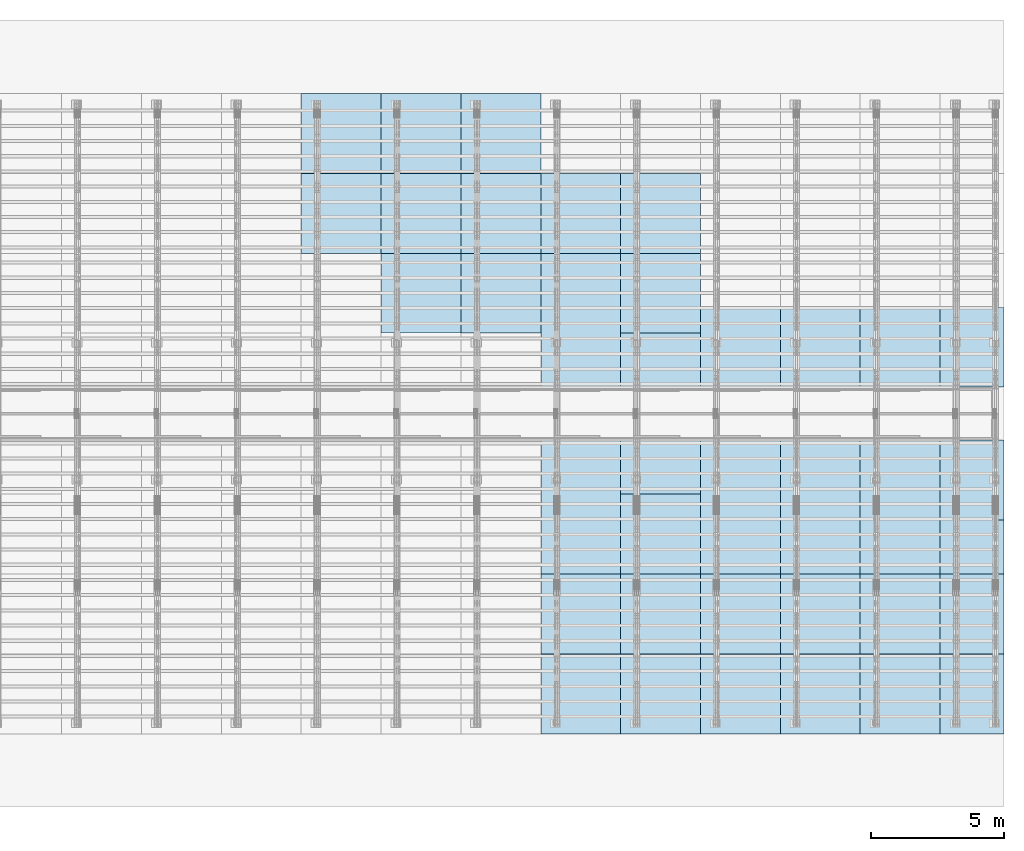
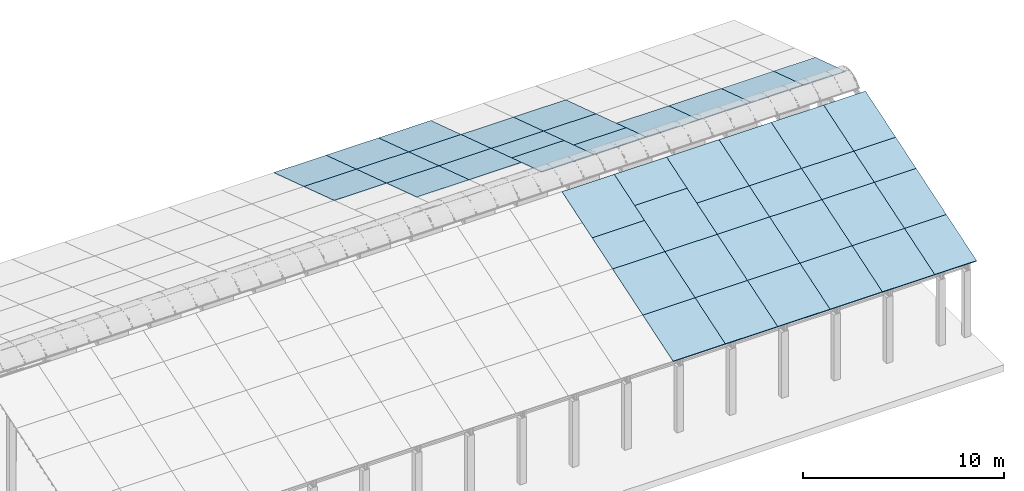
# One storey, part 9 of 385: 42 slabs, 42 elements without a shape of their own.
"""IFC2X3 building model written with IfcOpenShell, lengths in millimetres."""

from ifc_helpers import new_model, entity, si_unit, converted_unit, derived_unit, direction, frame, frame_2d, origin, place, context, subcontext, project, spatial, rectangle, extrude, material, layer, layer_set, element, aggregate, save


model = new_model("IFC2X3")

# Units and contexts
model_context = context("Model", 3, precision=0.01, world=origin(), true_north=direction((6.12303176911189e-17, 1.0)))
body_context = subcontext(model_context, "Body", "Model", "MODEL_VIEW")
ifc_project = project(units=[si_unit("LENGTHUNIT", "METRE", prefix="MILLI"), si_unit("AREAUNIT", "SQUARE_METRE"), si_unit("VOLUMEUNIT", "CUBIC_METRE"), converted_unit("PLANEANGLEUNIT", "DEGREE", entity("IfcRatioMeasure", 0.0174532925199433), si_unit("PLANEANGLEUNIT", "RADIAN"), dimensions=[0, 0, 0, 0, 0, 0, 0]), si_unit("MASSUNIT", "GRAM", prefix="KILO"), derived_unit("MASSDENSITYUNIT", [(si_unit("MASSUNIT", "GRAM", prefix="KILO"), 1), (si_unit("LENGTHUNIT", "METRE"), -3)]), si_unit("TIMEUNIT", "SECOND"), si_unit("FREQUENCYUNIT", "HERTZ"), si_unit("THERMODYNAMICTEMPERATUREUNIT", "DEGREE_CELSIUS"), derived_unit("THERMALTRANSMITTANCEUNIT", [(si_unit("MASSUNIT", "GRAM", prefix="KILO"), 1), (si_unit("THERMODYNAMICTEMPERATUREUNIT", "KELVIN"), -1), (si_unit("TIMEUNIT", "SECOND"), -3)]), derived_unit("VOLUMETRICFLOWRATEUNIT", [(si_unit("LENGTHUNIT", "METRE"), 3), (si_unit("TIMEUNIT", "SECOND"), -1)]), si_unit("ELECTRICCURRENTUNIT", "AMPERE"), si_unit("ELECTRICVOLTAGEUNIT", "VOLT"), si_unit("POWERUNIT", "WATT"), si_unit("FORCEUNIT", "NEWTON", prefix="KILO"), si_unit("ILLUMINANCEUNIT", "LUX"), si_unit("LUMINOUSFLUXUNIT", "LUMEN"), si_unit("LUMINOUSINTENSITYUNIT", "CANDELA"), derived_unit("USERDEFINED", [(si_unit("MASSUNIT", "GRAM", prefix="KILO"), -1), (si_unit("LENGTHUNIT", "METRE"), -2), (si_unit("TIMEUNIT", "SECOND"), 3), (si_unit("LUMINOUSFLUXUNIT", "LUMEN"), 1)]), derived_unit("LINEARVELOCITYUNIT", [(si_unit("LENGTHUNIT", "METRE"), 1), (si_unit("TIMEUNIT", "SECOND"), -1)]), si_unit("PRESSUREUNIT", "PASCAL"), derived_unit("USERDEFINED", [(si_unit("LENGTHUNIT", "METRE"), -2), (si_unit("MASSUNIT", "GRAM", prefix="KILO"), 1), (si_unit("TIMEUNIT", "SECOND"), -2)])], contexts=[model_context])

# Site, building, storey
site_placement = place(None, origin())
site = spatial("IfcSite", under=ifc_project, at=site_placement, CompositionType="ELEMENT")
building_placement = place(site_placement, origin())
building = spatial("IfcBuilding", under=site, at=building_placement, CompositionType="ELEMENT")
storey_placement = place(building_placement, origin())
storey = spatial("IfcBuildingStorey", under=building, at=storey_placement, Name="Default", CompositionType="ELEMENT", Elevation=0.0)

# Roof, slab
roof_1_placement = place(storey_placement, frame((23674.5090412161, 23742.4435684861, 594.897947736069)))
roof_1 = element("IfcRoof", 1, at=roof_1_placement, inside=storey, ShapeType="NOTDEFINED")
ifc_material = material()
ifc_layer = layer(ifc_material, 40.0)
ifc_layer_set = layer_set([ifc_layer])
slab_1_placement = place(roof_1_placement, origin())
slab_1 = element("IfcSlab", 2, at=slab_1_placement, material=ifc_layer_set, PredefinedType="ROOF", context=body_context, shape_type="SweptSolid", body=[
    extrude(rectangle(XDim=3154.3866727148, YDim=2999.99999999999, at=frame_2d((0.0, 2.1600499167107e-12), x_axis=(0.0, 1.0))), frame((1500.0, 1500.0, 487.379544349359), z_axis=(0.0, 0.309016994374947, 0.951056516295154), x_axis=(1.0, 0.0, 0.0)), (0.0, -0.309016994374947, 0.951056516295154), 42.0584889695308),
])
aggregate(roof_1, [slab_1])

roof_2_placement = place(storey_placement, frame((23674.5090412161, 20742.4435684861, 1569.65703643478)))
roof_2 = element("IfcRoof", 3, at=roof_2_placement, inside=storey, ShapeType="NOTDEFINED")
slab_2_placement = place(roof_2_placement, origin())
slab_2 = element("IfcSlab", 4, at=slab_2_placement, material=ifc_layer_set, PredefinedType="ROOF", context=body_context, shape_type="SweptSolid", body=[
    extrude(rectangle(XDim=3154.3866727148, YDim=2999.99999999999, at=frame_2d((-2.1600499167107e-12, 1.13686837721616e-13), x_axis=(0.0, 1.0))), frame((1500.0, 1500.0, 487.379544349359), z_axis=(0.0, 0.309016994374947, 0.951056516295154), x_axis=(1.0, 0.0, 0.0)), (0.0, -0.309016994374947, 0.951056516295154), 42.0584889695308),
])
aggregate(roof_2, [slab_2])

roof_3_placement = place(storey_placement, frame((26674.5090412161, 23742.4435684861, 594.897947736069)))
roof_3 = element("IfcRoof", 5, at=roof_3_placement, inside=storey, ShapeType="NOTDEFINED")
slab_3_placement = place(roof_3_placement, origin())
slab_3 = element("IfcSlab", 6, at=slab_3_placement, material=ifc_layer_set, PredefinedType="ROOF", context=body_context, shape_type="SweptSolid", body=[
    extrude(rectangle(XDim=3154.3866727148, YDim=2999.99999999999, at=frame_2d((0.0, 2.1600499167107e-12), x_axis=(0.0, 1.0))), frame((1500.0, 1500.0, 487.379544349359), z_axis=(0.0, 0.309016994374947, 0.951056516295154), x_axis=(1.0, 0.0, 0.0)), (0.0, -0.309016994374947, 0.951056516295154), 42.0584889695308),
])
aggregate(roof_3, [slab_3])

roof_4_placement = place(storey_placement, frame((26674.5090412161, 20742.4435684861, 1569.65703643478)))
roof_4 = element("IfcRoof", 7, at=roof_4_placement, inside=storey, ShapeType="NOTDEFINED")
slab_4_placement = place(roof_4_placement, origin())
slab_4 = element("IfcSlab", 8, at=slab_4_placement, material=ifc_layer_set, PredefinedType="ROOF", context=body_context, shape_type="SweptSolid", body=[
    extrude(rectangle(XDim=3154.3866727148, YDim=2999.99999999999, at=frame_2d((-2.1600499167107e-12, 1.13686837721616e-13), x_axis=(0.0, 1.0))), frame((1500.0, 1500.0, 487.379544349359), z_axis=(0.0, 0.309016994374947, 0.951056516295154), x_axis=(1.0, 0.0, 0.0)), (0.0, -0.309016994374947, 0.951056516295154), 42.0584889695308),
])
aggregate(roof_4, [slab_4])

roof_5_placement = place(storey_placement, frame((26674.5090412161, 17742.4435684861, 2544.4161251335)))
roof_5 = element("IfcRoof", 9, at=roof_5_placement, inside=storey, ShapeType="NOTDEFINED")
slab_5_placement = place(roof_5_placement, origin())
slab_5 = element("IfcSlab", 10, at=slab_5_placement, material=ifc_layer_set, PredefinedType="ROOF", context=body_context, shape_type="SweptSolid", body=[
    extrude(rectangle(XDim=3154.3866727148, YDim=2999.99999999999, at=frame_2d((0.0, 1.13686837721616e-12), x_axis=(0.0, 1.0))), frame((1500.0, 1500.0, 487.379544349359), z_axis=(0.0, 0.309016994374947, 0.951056516295154), x_axis=(1.0, 0.0, 0.0)), (0.0, -0.309016994374947, 0.951056516295154), 42.0584889695308),
])
aggregate(roof_5, [slab_5])

roof_6_placement = place(storey_placement, frame((29674.5090412161, 23742.4435684861, 594.897947736069)))
roof_6 = element("IfcRoof", 11, at=roof_6_placement, inside=storey, ShapeType="NOTDEFINED")
slab_6_placement = place(roof_6_placement, origin())
slab_6 = element("IfcSlab", 12, at=slab_6_placement, material=ifc_layer_set, PredefinedType="ROOF", context=body_context, shape_type="SweptSolid", body=[
    extrude(rectangle(XDim=3154.3866727148, YDim=2999.99999999999, at=frame_2d((0.0, 2.1600499167107e-12), x_axis=(0.0, 1.0))), frame((1500.0, 1500.0, 487.379544349359), z_axis=(0.0, 0.309016994374947, 0.951056516295154), x_axis=(1.0, 0.0, 0.0)), (0.0, -0.309016994374947, 0.951056516295154), 42.0584889695308),
])
aggregate(roof_6, [slab_6])

roof_7_placement = place(storey_placement, frame((29674.5090412161, 20742.4435684861, 1569.65703643478)))
roof_7 = element("IfcRoof", 13, at=roof_7_placement, inside=storey, ShapeType="NOTDEFINED")
slab_7_placement = place(roof_7_placement, origin())
slab_7 = element("IfcSlab", 14, at=slab_7_placement, material=ifc_layer_set, PredefinedType="ROOF", context=body_context, shape_type="SweptSolid", body=[
    extrude(rectangle(XDim=3154.3866727148, YDim=2999.99999999999, at=frame_2d((-2.1600499167107e-12, 1.13686837721616e-13), x_axis=(0.0, 1.0))), frame((1500.0, 1500.0, 487.379544349359), z_axis=(0.0, 0.309016994374947, 0.951056516295154), x_axis=(1.0, 0.0, 0.0)), (0.0, -0.309016994374947, 0.951056516295154), 42.0584889695308),
])
aggregate(roof_7, [slab_7])

roof_8_placement = place(storey_placement, frame((29674.5090412161, 17742.4435684861, 2544.4161251335)))
roof_8 = element("IfcRoof", 15, at=roof_8_placement, inside=storey, ShapeType="NOTDEFINED")
slab_8_placement = place(roof_8_placement, origin())
slab_8 = element("IfcSlab", 16, at=slab_8_placement, material=ifc_layer_set, PredefinedType="ROOF", context=body_context, shape_type="SweptSolid", body=[
    extrude(rectangle(XDim=3154.3866727148, YDim=2999.99999999999, at=frame_2d((0.0, 1.13686837721616e-12), x_axis=(0.0, 1.0))), frame((1500.0, 1500.0, 487.379544349359), z_axis=(0.0, 0.309016994374947, 0.951056516295154), x_axis=(1.0, 0.0, 0.0)), (0.0, -0.309016994374947, 0.951056516295154), 42.0584889695308),
])
aggregate(roof_8, [slab_8])

roof_9_placement = place(storey_placement, frame((32674.5090412161, 2697.55668997133, 594.897947736069)))
roof_9 = element("IfcRoof", 17, at=roof_9_placement, inside=storey, ShapeType="NOTDEFINED")
slab_9_placement = place(roof_9_placement, origin())
slab_9 = element("IfcSlab", 18, at=slab_9_placement, material=ifc_layer_set, PredefinedType="ROOF", context=body_context, shape_type="SweptSolid", body=[
    extrude(rectangle(XDim=3154.3866727148, YDim=2999.99999999999, at=frame_2d((0.0, 5.6843418860808e-13), x_axis=(0.0, -1.0))), frame((1500.0, 1500.0, 487.379544349359), z_axis=(0.0, -0.309016994374947, 0.951056516295154), x_axis=(1.0, 0.0, 0.0)), (0.0, 0.309016994374947, 0.951056516295154), 42.0584889695306),
])
aggregate(roof_9, [slab_9])

roof_10_placement = place(storey_placement, frame((32674.5090412161, 5697.55668997134, 1569.65703643478)))
roof_10 = element("IfcRoof", 19, at=roof_10_placement, inside=storey, ShapeType="NOTDEFINED")
slab_10_placement = place(roof_10_placement, origin())
slab_10 = element("IfcSlab", 20, at=slab_10_placement, material=ifc_layer_set, PredefinedType="ROOF", context=body_context, shape_type="SweptSolid", body=[
    extrude(rectangle(XDim=3154.3866727148, YDim=2999.99999999999, at=frame_2d((0.0, 6.82121026329696e-13), x_axis=(0.0, -1.0))), frame((1500.0, 1500.0, 487.379544349359), z_axis=(0.0, -0.309016994374947, 0.951056516295154), x_axis=(1.0, 0.0, 0.0)), (0.0, 0.309016994374947, 0.951056516295154), 42.0584889695306),
])
aggregate(roof_10, [slab_10])

roof_11_placement = place(storey_placement, frame((32674.5090412161, 8697.55668997135, 2544.4161251335)))
roof_11 = element("IfcRoof", 21, at=roof_11_placement, inside=storey, ShapeType="NOTDEFINED")
slab_11_placement = place(roof_11_placement, origin())
slab_11 = element("IfcSlab", 22, at=slab_11_placement, material=ifc_layer_set, PredefinedType="ROOF", context=body_context, shape_type="SweptSolid", body=[
    extrude(rectangle(XDim=3154.38667271481, YDim=2999.99999999999, at=frame_2d((0.0, 3.41060513164848e-13), x_axis=(0.0, -1.0))), frame((1500.0, 1500.0, 487.37954434936), z_axis=(0.0, -0.309016994374947, 0.951056516295154), x_axis=(1.0, 0.0, 0.0)), (0.0, 0.309016994374947, 0.951056516295154), 42.0584889695308),
])
aggregate(roof_11, [slab_11])

roof_12_placement = place(storey_placement, frame((32674.5090412161, 20742.4435684861, 1569.65703643478)))
roof_12 = element("IfcRoof", 23, at=roof_12_placement, inside=storey, ShapeType="NOTDEFINED")
slab_12_placement = place(roof_12_placement, origin())
slab_12 = element("IfcSlab", 24, at=slab_12_placement, material=ifc_layer_set, PredefinedType="ROOF", context=body_context, shape_type="SweptSolid", body=[
    extrude(rectangle(XDim=3154.3866727148, YDim=2999.99999999999, at=frame_2d((-2.1600499167107e-12, 1.13686837721616e-13), x_axis=(0.0, 1.0))), frame((1500.0, 1500.0, 487.379544349359), z_axis=(0.0, 0.309016994374947, 0.951056516295154), x_axis=(1.0, 0.0, 0.0)), (0.0, -0.309016994374947, 0.951056516295154), 42.0584889695308),
])
aggregate(roof_12, [slab_12])

roof_13_placement = place(storey_placement, frame((32674.5090412161, 17742.4435684861, 2544.4161251335)))
roof_13 = element("IfcRoof", 25, at=roof_13_placement, inside=storey, ShapeType="NOTDEFINED")
slab_13_placement = place(roof_13_placement, origin())
slab_13 = element("IfcSlab", 26, at=slab_13_placement, material=ifc_layer_set, PredefinedType="ROOF", context=body_context, shape_type="SweptSolid", body=[
    extrude(rectangle(XDim=3154.3866727148, YDim=2999.99999999999, at=frame_2d((0.0, 1.13686837721616e-12), x_axis=(0.0, 1.0))), frame((1500.0, 1500.0, 487.379544349359), z_axis=(0.0, 0.309016994374947, 0.951056516295154), x_axis=(1.0, 0.0, 0.0)), (0.0, -0.309016994374947, 0.951056516295154), 42.0584889695308),
])
aggregate(roof_13, [slab_13])

roof_14_placement = place(storey_placement, frame((32674.5090412161, 15713.9166481202, 3203.52447589904)))
roof_14 = element("IfcRoof", 27, at=roof_14_placement, inside=storey, ShapeType="NOTDEFINED")
slab_14_placement = place(roof_14_placement, origin())
slab_14 = element("IfcSlab", 28, at=slab_14_placement, material=ifc_layer_set, PredefinedType="ROOF", context=body_context, shape_type="SweptSolid", body=[
    extrude(rectangle(XDim=3154.3866727148, YDim=2999.99999999999, at=frame_2d((0.0, 1.13686837721616e-12), x_axis=(0.0, 1.0))), frame((1500.0, 1500.0, 487.379544349359), z_axis=(0.0, 0.309016994374947, 0.951056516295154), x_axis=(1.0, 0.0, 0.0)), (0.0, -0.309016994374947, 0.951056516295154), 42.0584889695308),
])
aggregate(roof_14, [slab_14])

roof_15_placement = place(storey_placement, frame((32674.5090412161, 10724.995992401, 3203.1710874096)))
roof_15 = element("IfcRoof", 29, at=roof_15_placement, inside=storey, ShapeType="NOTDEFINED")
slab_15_placement = place(roof_15_placement, origin())
slab_15 = element("IfcSlab", 30, at=slab_15_placement, material=ifc_layer_set, PredefinedType="ROOF", context=body_context, shape_type="SweptSolid", body=[
    extrude(rectangle(XDim=3154.3866727148, YDim=2999.99999999999, at=frame_2d((0.0, 0.0), x_axis=(0.0, -1.0))), frame((1500.0, 1500.0, 487.379544349359), z_axis=(0.0, -0.309016994374947, 0.951056516295154), x_axis=(1.0, 0.0, 0.0)), (0.0, 0.309016994374947, 0.951056516295154), 42.0584889695308),
])
aggregate(roof_15, [slab_15])

roof_16_placement = place(storey_placement, frame((35674.5090412161, 2697.55668997133, 594.897947736069)))
roof_16 = element("IfcRoof", 31, at=roof_16_placement, inside=storey, ShapeType="NOTDEFINED")
slab_16_placement = place(roof_16_placement, origin())
slab_16 = element("IfcSlab", 32, at=slab_16_placement, material=ifc_layer_set, PredefinedType="ROOF", context=body_context, shape_type="SweptSolid", body=[
    extrude(rectangle(XDim=3154.3866727148, YDim=2999.99999999999, at=frame_2d((0.0, 0.0), x_axis=(0.0, -1.0))), frame((1500.0, 1500.0, 487.379544349359), z_axis=(0.0, -0.309016994374947, 0.951056516295154), x_axis=(1.0, 0.0, 0.0)), (0.0, 0.309016994374947, 0.951056516295154), 42.0584889695306),
])
aggregate(roof_16, [slab_16])

roof_17_placement = place(storey_placement, frame((35674.5090412161, 5697.55668997133, 1569.65703643478)))
roof_17 = element("IfcRoof", 33, at=roof_17_placement, inside=storey, ShapeType="NOTDEFINED")
slab_17_placement = place(roof_17_placement, origin())
slab_17 = element("IfcSlab", 34, at=slab_17_placement, material=ifc_layer_set, PredefinedType="ROOF", context=body_context, shape_type="SweptSolid", body=[
    extrude(rectangle(XDim=3154.3866727148, YDim=2999.99999999999, at=frame_2d((0.0, 1.13686837721616e-13), x_axis=(0.0, -1.0))), frame((1500.0, 1500.0, 487.379544349359), z_axis=(0.0, -0.309016994374947, 0.951056516295154), x_axis=(1.0, 0.0, 0.0)), (0.0, 0.309016994374947, 0.951056516295154), 42.0584889695306),
])
aggregate(roof_17, [slab_17])

roof_18_placement = place(storey_placement, frame((35674.5090412161, 8697.55668997134, 2544.4161251335)))
roof_18 = element("IfcRoof", 35, at=roof_18_placement, inside=storey, ShapeType="NOTDEFINED")
slab_18_placement = place(roof_18_placement, origin())
slab_18 = element("IfcSlab", 36, at=slab_18_placement, material=ifc_layer_set, PredefinedType="ROOF", context=body_context, shape_type="SweptSolid", body=[
    extrude(rectangle(XDim=3154.38667271481, YDim=2999.99999999999, at=frame_2d((0.0, 0.0), x_axis=(0.0, -1.0))), frame((1500.0, 1500.0, 487.379544349361), z_axis=(0.0, -0.309016994374947, 0.951056516295154), x_axis=(1.0, 0.0, 0.0)), (0.0, 0.309016994374947, 0.951056516295154), 42.0584889695303),
])
aggregate(roof_18, [slab_18])

roof_19_placement = place(storey_placement, frame((35674.5090412161, 20742.4435684861, 1569.65703643478)))
roof_19 = element("IfcRoof", 37, at=roof_19_placement, inside=storey, ShapeType="NOTDEFINED")
slab_19_placement = place(roof_19_placement, origin())
slab_19 = element("IfcSlab", 38, at=slab_19_placement, material=ifc_layer_set, PredefinedType="ROOF", context=body_context, shape_type="SweptSolid", body=[
    extrude(rectangle(XDim=3154.3866727148, YDim=2999.99999999999, at=frame_2d((-2.1600499167107e-12, 1.13686837721616e-13), x_axis=(0.0, 1.0))), frame((1500.0, 1500.0, 487.379544349359), z_axis=(0.0, 0.309016994374947, 0.951056516295154), x_axis=(1.0, 0.0, 0.0)), (0.0, -0.309016994374947, 0.951056516295154), 42.0584889695308),
])
aggregate(roof_19, [slab_19])

roof_20_placement = place(storey_placement, frame((35674.5090412161, 17742.4435684861, 2544.4161251335)))
roof_20 = element("IfcRoof", 39, at=roof_20_placement, inside=storey, ShapeType="NOTDEFINED")
slab_20_placement = place(roof_20_placement, origin())
slab_20 = element("IfcSlab", 40, at=slab_20_placement, material=ifc_layer_set, PredefinedType="ROOF", context=body_context, shape_type="SweptSolid", body=[
    extrude(rectangle(XDim=3154.3866727148, YDim=2999.99999999999, at=frame_2d((0.0, 1.13686837721616e-12), x_axis=(0.0, 1.0))), frame((1500.0, 1500.0, 487.379544349359), z_axis=(0.0, 0.309016994374947, 0.951056516295154), x_axis=(1.0, 0.0, 0.0)), (0.0, -0.309016994374947, 0.951056516295154), 42.0584889695308),
])
aggregate(roof_20, [slab_20])

roof_21_placement = place(storey_placement, frame((35674.5090412161, 15713.9166481202, 3203.52447589904)))
roof_21 = element("IfcRoof", 41, at=roof_21_placement, inside=storey, ShapeType="NOTDEFINED")
slab_21_placement = place(roof_21_placement, origin())
slab_21 = element("IfcSlab", 42, at=slab_21_placement, material=ifc_layer_set, PredefinedType="ROOF", context=body_context, shape_type="SweptSolid", body=[
    extrude(rectangle(XDim=3154.3866727148, YDim=2999.99999999999, at=frame_2d((0.0, 1.13686837721616e-12), x_axis=(0.0, 1.0))), frame((1500.0, 1500.0, 487.379544349359), z_axis=(0.0, 0.309016994374947, 0.951056516295154), x_axis=(1.0, 0.0, 0.0)), (0.0, -0.309016994374947, 0.951056516295154), 42.0584889695308),
])
aggregate(roof_21, [slab_21])

roof_22_placement = place(storey_placement, frame((35674.5090412161, 10724.995992401, 3203.1710874096)))
roof_22 = element("IfcRoof", 43, at=roof_22_placement, inside=storey, ShapeType="NOTDEFINED")
slab_22_placement = place(roof_22_placement, origin())
slab_22 = element("IfcSlab", 44, at=slab_22_placement, material=ifc_layer_set, PredefinedType="ROOF", context=body_context, shape_type="SweptSolid", body=[
    extrude(rectangle(XDim=3154.3866727148, YDim=2999.99999999999, at=frame_2d((0.0, 0.0), x_axis=(0.0, -1.0))), frame((1500.0, 1500.0, 487.379544349359), z_axis=(0.0, -0.309016994374947, 0.951056516295154), x_axis=(1.0, 0.0, 0.0)), (0.0, 0.309016994374947, 0.951056516295154), 42.0584889695308),
])
aggregate(roof_22, [slab_22])

roof_23_placement = place(storey_placement, frame((38674.5090412161, 2697.55668997132, 594.897947736069)))
roof_23 = element("IfcRoof", 45, at=roof_23_placement, inside=storey, ShapeType="NOTDEFINED")
slab_23_placement = place(roof_23_placement, origin())
slab_23 = element("IfcSlab", 46, at=slab_23_placement, material=ifc_layer_set, PredefinedType="ROOF", context=body_context, shape_type="SweptSolid", body=[
    extrude(rectangle(XDim=3154.3866727148, YDim=2999.99999999999, at=frame_2d((0.0, 5.6843418860808e-13), x_axis=(0.0, -1.0))), frame((1500.0, 1500.0, 487.379544349359), z_axis=(0.0, -0.309016994374947, 0.951056516295154), x_axis=(1.0, 0.0, 0.0)), (0.0, 0.309016994374947, 0.951056516295154), 42.0584889695306),
])
aggregate(roof_23, [slab_23])

roof_24_placement = place(storey_placement, frame((38674.5090412161, 5697.55668997132, 1569.65703643478)))
roof_24 = element("IfcRoof", 47, at=roof_24_placement, inside=storey, ShapeType="NOTDEFINED")
slab_24_placement = place(roof_24_placement, origin())
slab_24 = element("IfcSlab", 48, at=slab_24_placement, material=ifc_layer_set, PredefinedType="ROOF", context=body_context, shape_type="SweptSolid", body=[
    extrude(rectangle(XDim=3154.3866727148, YDim=2999.99999999999, at=frame_2d((0.0, 6.82121026329696e-13), x_axis=(0.0, -1.0))), frame((1500.0, 1500.0, 487.379544349359), z_axis=(0.0, -0.309016994374947, 0.951056516295154), x_axis=(1.0, 0.0, 0.0)), (0.0, 0.309016994374947, 0.951056516295154), 42.0584889695306),
])
aggregate(roof_24, [slab_24])

roof_25_placement = place(storey_placement, frame((38674.5090412161, 8697.55668997133, 2544.4161251335)))
roof_25 = element("IfcRoof", 49, at=roof_25_placement, inside=storey, ShapeType="NOTDEFINED")
slab_25_placement = place(roof_25_placement, origin())
slab_25 = element("IfcSlab", 50, at=slab_25_placement, material=ifc_layer_set, PredefinedType="ROOF", context=body_context, shape_type="SweptSolid", body=[
    extrude(rectangle(XDim=3154.38667271481, YDim=2999.99999999999, at=frame_2d((0.0, -6.82121026329696e-13), x_axis=(0.0, -1.0))), frame((1500.0, 1500.0, 487.379544349361), z_axis=(0.0, -0.309016994374947, 0.951056516295154), x_axis=(1.0, 0.0, 0.0)), (0.0, 0.309016994374947, 0.951056516295154), 42.0584889695308),
])
aggregate(roof_25, [slab_25])

roof_26_placement = place(storey_placement, frame((38674.5090412161, 15713.9166481202, 3203.52447589904)))
roof_26 = element("IfcRoof", 51, at=roof_26_placement, inside=storey, ShapeType="NOTDEFINED")
slab_26_placement = place(roof_26_placement, origin())
slab_26 = element("IfcSlab", 52, at=slab_26_placement, material=ifc_layer_set, PredefinedType="ROOF", context=body_context, shape_type="SweptSolid", body=[
    extrude(rectangle(XDim=3154.3866727148, YDim=2999.99999999999, at=frame_2d((-2.1600499167107e-12, 1.13686837721616e-12), x_axis=(0.0, 1.0))), frame((1500.0, 1500.0, 487.379544349359), z_axis=(0.0, 0.309016994374947, 0.951056516295154), x_axis=(1.0, 0.0, 0.0)), (0.0, -0.309016994374947, 0.951056516295154), 42.0584889695308),
])
aggregate(roof_26, [slab_26])

roof_27_placement = place(storey_placement, frame((38674.5090412161, 10724.995992401, 3203.1710874096)))
roof_27 = element("IfcRoof", 53, at=roof_27_placement, inside=storey, ShapeType="NOTDEFINED")
slab_27_placement = place(roof_27_placement, origin())
slab_27 = element("IfcSlab", 54, at=slab_27_placement, material=ifc_layer_set, PredefinedType="ROOF", context=body_context, shape_type="SweptSolid", body=[
    extrude(rectangle(XDim=3154.3866727148, YDim=2999.99999999999, at=frame_2d((0.0, 0.0), x_axis=(0.0, -1.0))), frame((1500.0, 1500.0, 487.379544349359), z_axis=(0.0, -0.309016994374947, 0.951056516295154), x_axis=(1.0, 0.0, 0.0)), (0.0, 0.309016994374947, 0.951056516295154), 42.0584889695308),
])
aggregate(roof_27, [slab_27])

roof_28_placement = place(storey_placement, frame((41674.509041216, 2697.55668997131, 594.897947736069)))
roof_28 = element("IfcRoof", 55, at=roof_28_placement, inside=storey, ShapeType="NOTDEFINED")
slab_28_placement = place(roof_28_placement, origin())
slab_28 = element("IfcSlab", 56, at=slab_28_placement, material=ifc_layer_set, PredefinedType="ROOF", context=body_context, shape_type="SweptSolid", body=[
    extrude(rectangle(XDim=3154.3866727148, YDim=2999.99999999999, at=frame_2d((0.0, 0.0), x_axis=(0.0, -1.0))), frame((1500.0, 1500.0, 487.379544349359), z_axis=(0.0, -0.309016994374947, 0.951056516295154), x_axis=(1.0, 0.0, 0.0)), (0.0, 0.309016994374947, 0.951056516295154), 42.0584889695306),
])
aggregate(roof_28, [slab_28])

roof_29_placement = place(storey_placement, frame((41674.5090412161, 5697.55668997131, 1569.65703643478)))
roof_29 = element("IfcRoof", 57, at=roof_29_placement, inside=storey, ShapeType="NOTDEFINED")
slab_29_placement = place(roof_29_placement, origin())
slab_29 = element("IfcSlab", 58, at=slab_29_placement, material=ifc_layer_set, PredefinedType="ROOF", context=body_context, shape_type="SweptSolid", body=[
    extrude(rectangle(XDim=3154.3866727148, YDim=2999.99999999999, at=frame_2d((0.0, 1.13686837721616e-13), x_axis=(0.0, -1.0))), frame((1500.0, 1500.0, 487.379544349359), z_axis=(0.0, -0.309016994374947, 0.951056516295154), x_axis=(1.0, 0.0, 0.0)), (0.0, 0.309016994374947, 0.951056516295154), 42.0584889695306),
])
aggregate(roof_29, [slab_29])

roof_30_placement = place(storey_placement, frame((41674.5090412161, 8697.55668997132, 2544.4161251335)))
roof_30 = element("IfcRoof", 59, at=roof_30_placement, inside=storey, ShapeType="NOTDEFINED")
slab_30_placement = place(roof_30_placement, origin())
slab_30 = element("IfcSlab", 60, at=slab_30_placement, material=ifc_layer_set, PredefinedType="ROOF", context=body_context, shape_type="SweptSolid", body=[
    extrude(rectangle(XDim=3154.38667271482, YDim=2999.99999999999, at=frame_2d((0.0, -1.25055521493778e-12), x_axis=(0.0, -1.0))), frame((1500.0, 1500.0, 487.379544349361), z_axis=(0.0, -0.309016994374947, 0.951056516295154), x_axis=(1.0, 0.0, 0.0)), (0.0, 0.309016994374947, 0.951056516295154), 42.0584889695308),
])
aggregate(roof_30, [slab_30])

roof_31_placement = place(storey_placement, frame((41674.5090412161, 15713.9166481202, 3203.52447589904)))
roof_31 = element("IfcRoof", 61, at=roof_31_placement, inside=storey, ShapeType="NOTDEFINED")
slab_31_placement = place(roof_31_placement, origin())
slab_31 = element("IfcSlab", 62, at=slab_31_placement, material=ifc_layer_set, PredefinedType="ROOF", context=body_context, shape_type="SweptSolid", body=[
    extrude(rectangle(XDim=3154.3866727148, YDim=2999.99999999999, at=frame_2d((0.0, 1.13686837721616e-12), x_axis=(0.0, 1.0))), frame((1500.0, 1500.0, 487.379544349359), z_axis=(0.0, 0.309016994374947, 0.951056516295154), x_axis=(1.0, 0.0, 0.0)), (0.0, -0.309016994374947, 0.951056516295154), 42.0584889695308),
])
aggregate(roof_31, [slab_31])

roof_32_placement = place(storey_placement, frame((41674.5090412161, 10724.995992401, 3203.1710874096)))
roof_32 = element("IfcRoof", 63, at=roof_32_placement, inside=storey, ShapeType="NOTDEFINED")
slab_32_placement = place(roof_32_placement, origin())
slab_32 = element("IfcSlab", 64, at=slab_32_placement, material=ifc_layer_set, PredefinedType="ROOF", context=body_context, shape_type="SweptSolid", body=[
    extrude(rectangle(XDim=3154.3866727148, YDim=2999.99999999999, at=frame_2d((0.0, 0.0), x_axis=(0.0, -1.0))), frame((1500.0, 1500.0, 487.379544349359), z_axis=(0.0, -0.309016994374947, 0.951056516295154), x_axis=(1.0, 0.0, 0.0)), (0.0, 0.309016994374947, 0.951056516295154), 42.0584889695308),
])
aggregate(roof_32, [slab_32])

roof_33_placement = place(storey_placement, frame((44674.509041216, 2697.5566899713, 594.897947736069)))
roof_33 = element("IfcRoof", 65, at=roof_33_placement, inside=storey, ShapeType="NOTDEFINED")
slab_33_placement = place(roof_33_placement, origin())
slab_33 = element("IfcSlab", 66, at=slab_33_placement, material=ifc_layer_set, PredefinedType="ROOF", context=body_context, shape_type="SweptSolid", body=[
    extrude(rectangle(XDim=3154.3866727148, YDim=2999.99999999999, at=frame_2d((0.0, 5.6843418860808e-13), x_axis=(0.0, -1.0))), frame((1500.0, 1500.0, 487.379544349359), z_axis=(0.0, -0.309016994374947, 0.951056516295154), x_axis=(1.0, 0.0, 0.0)), (0.0, 0.309016994374947, 0.951056516295154), 42.0584889695306),
])
aggregate(roof_33, [slab_33])

roof_34_placement = place(storey_placement, frame((44674.5090412161, 5697.5566899713, 1569.65703643478)))
roof_34 = element("IfcRoof", 67, at=roof_34_placement, inside=storey, ShapeType="NOTDEFINED")
slab_34_placement = place(roof_34_placement, origin())
slab_34 = element("IfcSlab", 68, at=slab_34_placement, material=ifc_layer_set, PredefinedType="ROOF", context=body_context, shape_type="SweptSolid", body=[
    extrude(rectangle(XDim=3154.3866727148, YDim=2999.99999999999, at=frame_2d((0.0, 6.82121026329696e-13), x_axis=(0.0, -1.0))), frame((1500.0, 1500.0, 487.379544349359), z_axis=(0.0, -0.309016994374947, 0.951056516295154), x_axis=(1.0, 0.0, 0.0)), (0.0, 0.309016994374947, 0.951056516295154), 42.0584889695306),
])
aggregate(roof_34, [slab_34])

roof_35_placement = place(storey_placement, frame((44674.5090412161, 8697.55668997131, 2544.4161251335)))
roof_35 = element("IfcRoof", 69, at=roof_35_placement, inside=storey, ShapeType="NOTDEFINED")
slab_35_placement = place(roof_35_placement, origin())
slab_35 = element("IfcSlab", 70, at=slab_35_placement, material=ifc_layer_set, PredefinedType="ROOF", context=body_context, shape_type="SweptSolid", body=[
    extrude(rectangle(XDim=3154.38667271482, YDim=2999.99999999999, at=frame_2d((0.0, 5.6843418860808e-13), x_axis=(0.0, -1.0))), frame((1500.0, 1500.0, 487.379544349361), z_axis=(0.0, -0.309016994374947, 0.951056516295154), x_axis=(1.0, 0.0, 0.0)), (0.0, 0.309016994374947, 0.951056516295154), 42.0584889695314),
])
aggregate(roof_35, [slab_35])

roof_36_placement = place(storey_placement, frame((44674.5090412161, 15713.9166481202, 3203.52447589904)))
roof_36 = element("IfcRoof", 71, at=roof_36_placement, inside=storey, ShapeType="NOTDEFINED")
slab_36_placement = place(roof_36_placement, origin())
slab_36 = element("IfcSlab", 72, at=slab_36_placement, material=ifc_layer_set, PredefinedType="ROOF", context=body_context, shape_type="SweptSolid", body=[
    extrude(rectangle(XDim=3154.3866727148, YDim=2999.99999999999, at=frame_2d((0.0, 1.13686837721616e-12), x_axis=(0.0, 1.0))), frame((1500.0, 1500.0, 487.379544349359), z_axis=(0.0, 0.309016994374947, 0.951056516295154), x_axis=(1.0, 0.0, 0.0)), (0.0, -0.309016994374947, 0.951056516295154), 42.0584889695308),
])
aggregate(roof_36, [slab_36])

roof_37_placement = place(storey_placement, frame((44674.5090412161, 10724.995992401, 3203.1710874096)))
roof_37 = element("IfcRoof", 73, at=roof_37_placement, inside=storey, ShapeType="NOTDEFINED")
slab_37_placement = place(roof_37_placement, origin())
slab_37 = element("IfcSlab", 74, at=slab_37_placement, material=ifc_layer_set, PredefinedType="ROOF", context=body_context, shape_type="SweptSolid", body=[
    extrude(rectangle(XDim=3154.3866727148, YDim=2999.99999999999, at=frame_2d((0.0, 0.0), x_axis=(0.0, -1.0))), frame((1500.0, 1500.0, 487.379544349359), z_axis=(0.0, -0.309016994374947, 0.951056516295154), x_axis=(1.0, 0.0, 0.0)), (0.0, 0.309016994374947, 0.951056516295154), 42.0584889695308),
])
aggregate(roof_37, [slab_37])

roof_38_placement = place(storey_placement, frame((47674.509041216, 2697.55668997129, 594.897947736069)))
roof_38 = element("IfcRoof", 75, at=roof_38_placement, inside=storey, ShapeType="NOTDEFINED")
slab_38_placement = place(roof_38_placement, origin())
slab_38 = element("IfcSlab", 76, at=slab_38_placement, material=ifc_layer_set, PredefinedType="ROOF", context=body_context, shape_type="SweptSolid", body=[
    extrude(rectangle(XDim=3154.3866727148, YDim=2400.0, at=frame_2d((-4.32009983342141e-12, 0.0), x_axis=(0.0, -1.0))), frame((1200.0, 1500.0, 487.379544349359), z_axis=(0.0, -0.309016994374947, 0.951056516295154), x_axis=(1.0, 0.0, 0.0)), (0.0, 0.309016994374947, 0.951056516295154), 42.0584889695306),
])
aggregate(roof_38, [slab_38])

roof_39_placement = place(storey_placement, frame((47674.5090412161, 5697.55668997129, 1569.65703643478)))
roof_39 = element("IfcRoof", 77, at=roof_39_placement, inside=storey, ShapeType="NOTDEFINED")
slab_39_placement = place(roof_39_placement, origin())
slab_39 = element("IfcSlab", 78, at=slab_39_placement, material=ifc_layer_set, PredefinedType="ROOF", context=body_context, shape_type="SweptSolid", body=[
    extrude(rectangle(XDim=3154.3866727148, YDim=2400.0, at=frame_2d((-4.32009983342141e-12, 0.0), x_axis=(0.0, -1.0))), frame((1200.0, 1500.0, 487.379544349359), z_axis=(0.0, -0.309016994374947, 0.951056516295154), x_axis=(1.0, 0.0, 0.0)), (0.0, 0.309016994374947, 0.951056516295154), 42.0584889695308),
])
aggregate(roof_39, [slab_39])

roof_40_placement = place(storey_placement, frame((47674.5090412161, 8697.5566899713, 2544.4161251335)))
roof_40 = element("IfcRoof", 79, at=roof_40_placement, inside=storey, ShapeType="NOTDEFINED")
slab_40_placement = place(roof_40_placement, origin())
slab_40 = element("IfcSlab", 80, at=slab_40_placement, material=ifc_layer_set, PredefinedType="ROOF", context=body_context, shape_type="SweptSolid", body=[
    extrude(rectangle(XDim=3154.38667271482, YDim=2400.0, at=frame_2d((-4.32009983342141e-12, 0.0), x_axis=(0.0, -1.0))), frame((1200.0, 1500.0, 487.379544349361), z_axis=(0.0, -0.309016994374947, 0.951056516295154), x_axis=(1.0, 0.0, 0.0)), (0.0, 0.309016994374947, 0.951056516295154), 42.0584889695308),
])
aggregate(roof_40, [slab_40])

roof_41_placement = place(storey_placement, frame((47674.5090412161, 15713.9166481202, 3203.52447589904)))
roof_41 = element("IfcRoof", 81, at=roof_41_placement, inside=storey, ShapeType="NOTDEFINED")
slab_41_placement = place(roof_41_placement, origin())
slab_41 = element("IfcSlab", 82, at=slab_41_placement, material=ifc_layer_set, PredefinedType="ROOF", context=body_context, shape_type="SweptSolid", body=[
    extrude(rectangle(XDim=3154.3866727148, YDim=2400.0, at=frame_2d((4.32009983342141e-12, -1.02318153949454e-12), x_axis=(0.0, 1.0))), frame((1200.0, 1500.0, 487.379544349359), z_axis=(0.0, 0.309016994374947, 0.951056516295154), x_axis=(1.0, 0.0, 0.0)), (0.0, -0.309016994374947, 0.951056516295154), 42.0584889695308),
])
aggregate(roof_41, [slab_41])

roof_42_placement = place(storey_placement, frame((47674.5090412161, 10724.995992401, 3203.1710874096)))
roof_42 = element("IfcRoof", 83, at=roof_42_placement, inside=storey, ShapeType="NOTDEFINED")
slab_42_placement = place(roof_42_placement, origin())
slab_42 = element("IfcSlab", 84, at=slab_42_placement, material=ifc_layer_set, PredefinedType="ROOF", context=body_context, shape_type="SweptSolid", body=[
    extrude(rectangle(XDim=3154.3866727148, YDim=2400.0, at=frame_2d((-4.32009983342141e-12, 0.0), x_axis=(0.0, -1.0))), frame((1200.0, 1500.0, 487.379544349359), z_axis=(0.0, -0.309016994374947, 0.951056516295154), x_axis=(1.0, 0.0, 0.0)), (0.0, 0.309016994374947, 0.951056516295154), 42.0584889695308),
])
aggregate(roof_42, [slab_42])

save(model, "model.ifc")
